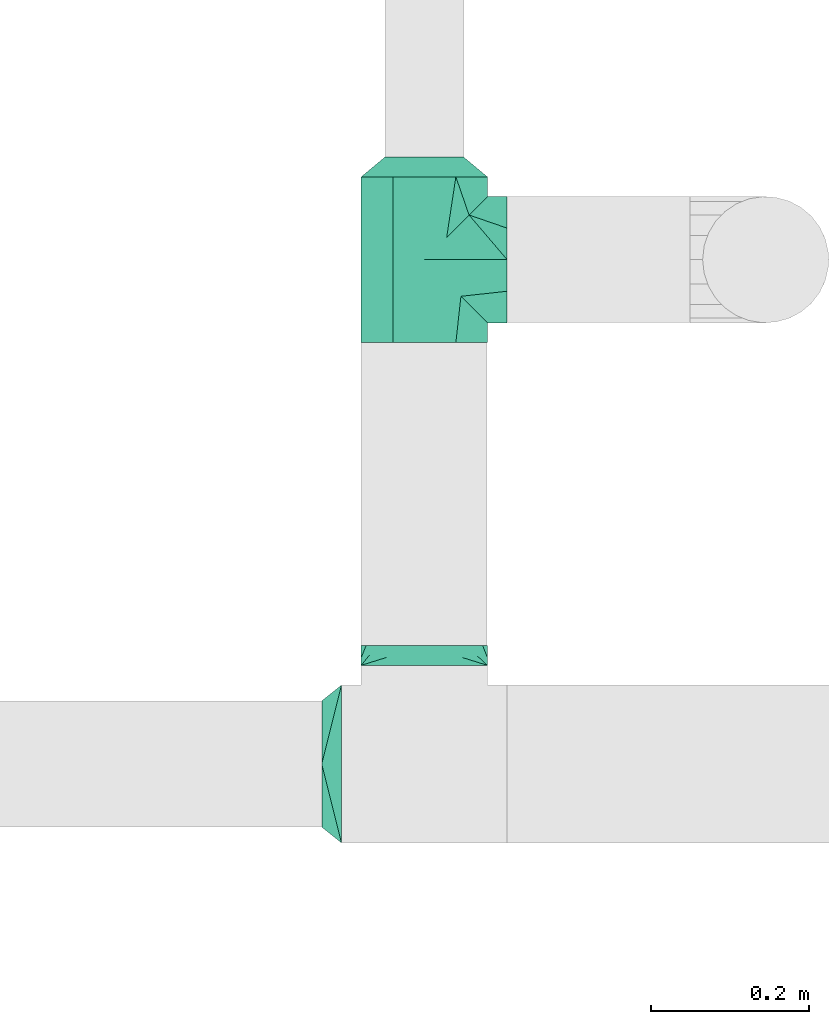
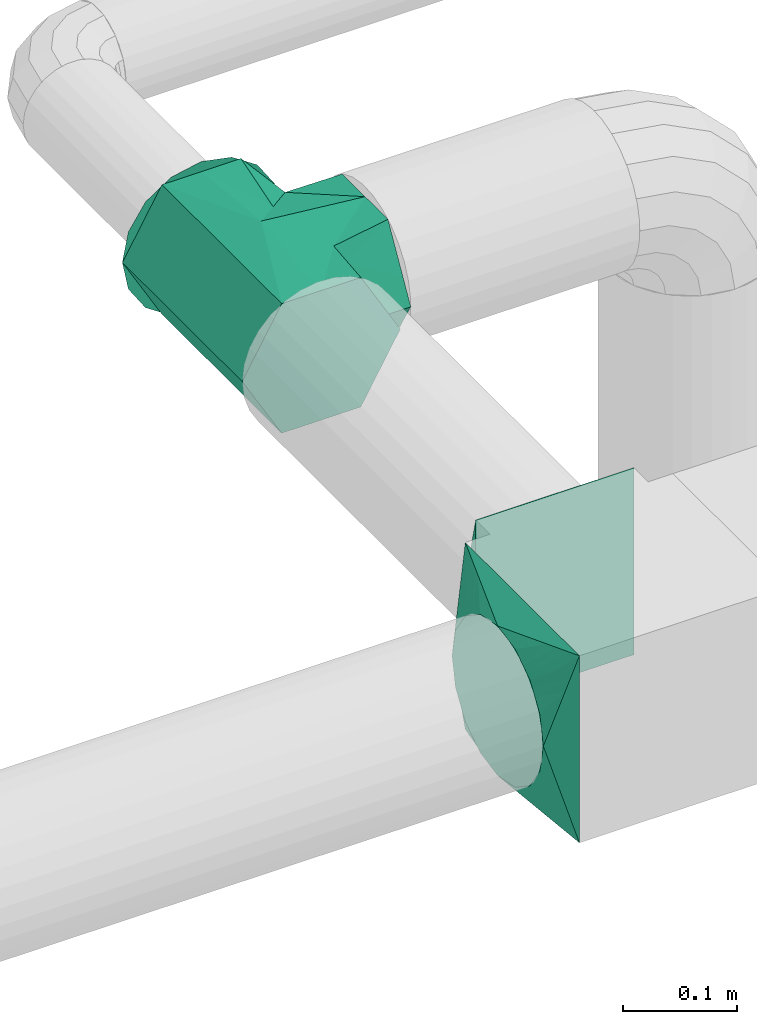
# One storey, part 4 of 5: 4 flow fittings.
"""IFC2X3 building model written with IfcOpenShell, lengths in millimetres."""

from ifc_helpers import new_model, entity, si_unit, converted_unit, derived_unit, direction, frame, origin, place, context, subcontext, project, spatial, faceted_brep, source, transform, mapped, material, material_list, type_object, type_shapes, element, save


model = new_model("IFC2X3")

# Units and contexts
model_context = context("Model", 3, precision=0.01, world=origin(), true_north=direction((6.12303176911189e-17, 1.0)))
body_context = subcontext(model_context, "Body", "Model", "MODEL_VIEW")
ifc_project = project(units=[si_unit("LENGTHUNIT", "METRE", prefix="MILLI"), si_unit("AREAUNIT", "SQUARE_METRE"), si_unit("VOLUMEUNIT", "CUBIC_METRE"), converted_unit("PLANEANGLEUNIT", "DEGREE", entity("IfcRatioMeasure", 0.0174532925199433), si_unit("PLANEANGLEUNIT", "RADIAN"), dimensions=[0, 0, 0, 0, 0, 0, 0]), si_unit("MASSUNIT", "GRAM", prefix="KILO"), derived_unit("MASSDENSITYUNIT", [(si_unit("MASSUNIT", "GRAM", prefix="KILO"), 1), (si_unit("LENGTHUNIT", "METRE"), -3)]), derived_unit("MOMENTOFINERTIAUNIT", [(si_unit("LENGTHUNIT", "METRE"), 4)]), si_unit("TIMEUNIT", "SECOND"), si_unit("FREQUENCYUNIT", "HERTZ"), si_unit("THERMODYNAMICTEMPERATUREUNIT", "DEGREE_CELSIUS"), derived_unit("THERMALTRANSMITTANCEUNIT", [(si_unit("MASSUNIT", "GRAM", prefix="KILO"), 1), (si_unit("THERMODYNAMICTEMPERATUREUNIT", "KELVIN"), -1), (si_unit("TIMEUNIT", "SECOND"), -3)]), derived_unit("VOLUMETRICFLOWRATEUNIT", [(si_unit("LENGTHUNIT", "METRE"), 3), (si_unit("TIMEUNIT", "SECOND"), -1)]), si_unit("ELECTRICCURRENTUNIT", "AMPERE"), si_unit("ELECTRICVOLTAGEUNIT", "VOLT"), si_unit("POWERUNIT", "WATT"), si_unit("FORCEUNIT", "NEWTON", prefix="KILO"), si_unit("ILLUMINANCEUNIT", "LUX"), si_unit("LUMINOUSFLUXUNIT", "LUMEN"), si_unit("LUMINOUSINTENSITYUNIT", "CANDELA"), derived_unit("USERDEFINED", [(si_unit("MASSUNIT", "GRAM", prefix="KILO"), -1), (si_unit("LENGTHUNIT", "METRE"), -2), (si_unit("TIMEUNIT", "SECOND"), 3), (si_unit("LUMINOUSFLUXUNIT", "LUMEN"), 1)]), derived_unit("LINEARVELOCITYUNIT", [(si_unit("LENGTHUNIT", "METRE"), 1), (si_unit("TIMEUNIT", "SECOND"), -1)]), si_unit("PRESSUREUNIT", "PASCAL"), derived_unit("USERDEFINED", [(si_unit("LENGTHUNIT", "METRE"), -2), (si_unit("MASSUNIT", "GRAM", prefix="KILO"), 1), (si_unit("TIMEUNIT", "SECOND"), -2)]), derived_unit("LINEARFORCEUNIT", [(si_unit("MASSUNIT", "GRAM", prefix="KILO"), 1), (si_unit("LENGTHUNIT", "METRE"), 1), (si_unit("TIMEUNIT", "SECOND"), -2), (si_unit("LENGTHUNIT", "METRE"), -1)]), derived_unit("PLANARFORCEUNIT", [(si_unit("MASSUNIT", "GRAM", prefix="KILO"), 1), (si_unit("LENGTHUNIT", "METRE"), 1), (si_unit("TIMEUNIT", "SECOND"), -2), (si_unit("LENGTHUNIT", "METRE"), -2)])], contexts=[model_context])

# Site, building, storey
site_placement = place(None, origin())
site = spatial("IfcSite", under=ifc_project, at=site_placement, CompositionType="ELEMENT")
building_placement = place(site_placement, origin())
building = spatial("IfcBuilding", under=site, at=building_placement, CompositionType="ELEMENT")
storey_placement = place(building_placement, frame((0.0, 0.0, 12000.0)))
storey = spatial("IfcBuildingStorey", under=building, at=storey_placement, Name="03 Level", CompositionType="ELEMENT", Elevation=12000.0)

# Flow fittings
duct_fitting_type_1 = type_object("IfcDuctFittingType", Name="tee_90_001:Air_Tee 90_Circ", PredefinedType="NOTDEFINED")
shared_shape_1 = source(origin(), body_context, "Body", "Brep", [
    faceted_brep([(-105.0, -40.0, -69.2820323027551), (-105.0, -60.0, -34.6410161513775), (-105.0, -80.0, 0.0), (-105.0, -60.0, 34.641016151378), (-105.0, -40.0, 69.2820323027556), (-105.0, 0.0, 69.2820323027551), (-105.0, 40.0, 69.2820323027547), (-105.0, 50.0, 51.9615242270659), (-105.0, 60.0, 34.6410161513772), (-105.0, 70.0, 17.3205080756885), (-105.0, 80.0, 0.0), (-105.0, 60.0, -34.6410161513777), (-105.0, 40.0, -69.2820323027552), (-105.0, 0.0, -69.2820323027551), (105.0, 80.0, 0.0), (105.0, 60.0, 34.6410161513772), (105.0, 40.0, 69.2820323027547), (105.0, 0.0, 69.2820323027551), (105.0, -40.0, 69.2820323027556), (105.0, -65.7984888459213, 24.5977388631201), (105.0, -80.0, 0.0), (105.0, -60.0, -34.6410161513775), (105.0, -40.0, -69.2820323027551), (105.0, 0.0, -69.2820323027551), (105.0, 40.0, -69.2820323027552), (105.0, 50.0, -51.9615242270664), (105.0, 60.0, -34.6410161513777), (105.0, 70.0, -17.320508075689), (63.1985060310392, 63.1985060310395, 32.5857226086492), (46.3970120620784, 46.3970120620786, 65.1714452172986), (80.0, 80.0, 0.0), (0.0, 0.0, 80.0), (-56.6842556369155, 56.6842556369154, 56.452592171563), (-68.3421278184578, 68.3421278184576, 28.2262960857814), (-28.3421278184578, 28.3421278184581, 68.2262960857815), (-74.1710639092289, 74.1710639092287, 14.1131480428906), (54.7977590465588, 54.7977590465591, 48.878583912974), (-74.6766712784703, 74.6766712784701, 12.8889603793856), (-80.0, 80.0, 0.0), (56.6842556369152, 56.6842556369155, -56.4525921715632), (-46.3970120620782, 46.3970120620781, -65.1714452172987), (0.0, 0.0, -80.0), (-63.1985060310391, 63.198506031039, -32.5857226086494), (28.3421278184576, 28.3421278184579, -68.2262960857816), (74.1710639092288, 74.1710639092291, -14.113148042891), (68.3421278184576, 68.3421278184579, -28.2262960857817), (74.6766712820988, 74.6766712820991, -12.8889603706002), (-80.0, 105.0, 0.0), (-60.0, 105.0, 34.6410161513772), (-40.0, 105.0, 69.2820323027547), (0.0, 105.0, 69.2820323027551), (40.0, 105.0, 69.2820323027556), (65.7984884413447, 105.0, 24.5977395638678), (80.0, 105.0, 0.0), (60.0, 105.0, -34.6410161513775), (40.0, 105.0, -69.2820323027551), (0.0, 105.0, -69.2820323027551), (-40.0, 105.0, -69.2820323027552), (-60.0, 105.0, -34.6410161513777), (-72.8992433944082, 105.0, -12.2988712130655)], [[[0, 1, 2, 3, 4, 5, 6, 7, 8, 9, 10, 11, 12, 13]], [[14, 15, 16, 17, 18, 19, 20, 21, 22, 23, 24, 25, 26, 27]], [[15, 14, 28]], [[16, 15, 29]], [[30, 28, 14]], [[5, 4, 31]], [[8, 32, 33]], [[8, 7, 6, 32]], [[34, 32, 6]], [[33, 35, 9]], [[31, 17, 29]], [[15, 28, 36, 29]], [[18, 17, 31]], [[2, 20, 19, 18, 4, 3]], [[6, 5, 34]], [[34, 5, 31]], [[9, 35, 10]], [[18, 31, 4]], [[9, 8, 33]], [[17, 16, 29]], [[10, 35, 37, 38]], [[21, 20, 2, 1, 0, 22]], [[25, 24, 39, 26]], [[12, 40, 13]], [[41, 22, 0]], [[41, 13, 40]], [[41, 0, 13]], [[42, 40, 11]], [[43, 24, 23]], [[27, 44, 14]], [[27, 45, 44]], [[27, 26, 45]], [[14, 44, 46, 30]], [[39, 45, 26]], [[43, 39, 24]], [[10, 42, 11]], [[38, 42, 10]], [[23, 22, 41]], [[12, 11, 40]], [[43, 23, 41]], [[47, 48, 49, 50, 51, 52, 53, 54, 55, 56, 57, 58, 59]], [[38, 37, 47]], [[28, 30, 52, 36]], [[33, 32, 48, 37, 35]], [[50, 49, 32]], [[51, 36, 52]], [[29, 36, 51]], [[31, 29, 50]], [[50, 32, 34, 31]], [[30, 53, 52]], [[32, 49, 48]], [[47, 37, 48]], [[29, 51, 50]], [[30, 46, 53]], [[54, 46, 44, 45, 39]], [[59, 58, 57, 42]], [[56, 55, 39]], [[39, 55, 54]], [[47, 59, 38]], [[40, 42, 57]], [[38, 59, 42]], [[56, 39, 43, 41]], [[41, 40, 56]], [[40, 57, 56]], [[53, 46, 54]]]),
])
type_shapes(duct_fitting_type_1, [shared_shape_1])
flow_fitting_1_placement = place(storey_placement, frame((23185.9900708518, -67867.2449387878, 3000.0), z_axis=(0.0, 0.0, 1.0), x_axis=(0.0, -1.0, 0.0)))
element("IfcFlowFitting", 1, at=flow_fitting_1_placement, inside=storey, type_object=duct_fitting_type_1, Name="tee_90_001:Air_Tee 90_Circ", ObjectType="tee_90_001:Air_Tee 90_Circ", context=body_context, shape_type="MappedRepresentation", body=[
    mapped(shared_shape_1, transform((0.0, 0.0, 0.0), scale=1.0)),
])
ifc_material_1 = material(Name="Material_Duct")
ifc_material_2 = material(Name="Material_Lining")
ifc_material_3 = material(Name="Material_Ins")
ifc_material_list_1 = material_list([ifc_material_2, ifc_material_3, ifc_material_1])
duct_fitting_type_2 = type_object("IfcDuctFittingType", Name="reduction_001:Air_Reduction_Circ", PredefinedType="NOTDEFINED", material=ifc_material_list_1)
shared_shape_2 = source(origin(), body_context, "Body", "Brep", [
    faceted_brep([(25.0, 45.0484433951223, -21.6941869558729), (25.0, 47.5242216975607, -10.8470934779334), (25.0, 50.0, 0.0), (25.0, 47.5242216975601, 10.8470934779448), (25.0, 45.0484433951193, 21.6941869558836), (25.0, 38.1114667440265, 30.3928805396443), (25.0, 31.1744900929338, 39.0915741234051), (25.0, 21.1502683953737, 43.9189848662489), (25.0, 11.1260466978137, 48.7463956090927), (25.0, 0.0, 48.7463956090925), (25.0, -11.1260466978156, 48.7463956090923), (25.0, -21.1502683953754, 43.9189848662482), (25.0, -31.1744900929351, 39.0915741234041), (25.0, -38.1114667440274, 30.3928805396434), (25.0, -45.0484433951197, 21.6941869558827), (25.0, -47.5242216975603, 10.8470934779443), (25.0, -50.0, 0.0), (25.0, -47.5242216975608, -10.8470934779335), (25.0, -45.0484433951224, -21.6941869558726), (25.0, -38.1114667440309, -30.3928805396354), (25.0, -31.1744900929393, -39.0915741233981), (25.0, -21.1502683953783, -43.9189848662439), (25.0, -11.1260466978174, -48.7463956090898), (25.0, 0.0, -48.7463956090899), (25.0, 11.1260466978161, -48.74639560909), (25.0, 21.1502683953773, -43.9189848662444), (25.0, 31.1744900929385, -39.0915741233988), (25.0, 38.1114667440304, -30.3928805396358), (0.0, 80.0, 0.0), (0.0, 76.9551813004531, -15.307337294604), (0.0, 73.9103626009062, -30.6146745892082), (0.0, 65.2394525479173, -43.5916085420681), (0.0, 56.5685424949284, -56.5685424949279), (0.0, 43.5916085420694, -65.2394525479189), (0.0, 30.6146745892104, -73.9103626009099), (0.0, 15.3073372946054, -76.9551813004588), (0.0, 0.0, -80.0), (0.0, -15.3073372946045, -76.9551813004584), (0.0, -30.6146745892093, -73.9103626009091), (0.0, -43.5916085420678, -65.239452547918), (0.0, -56.5685424949263, -56.568542494927), (0.0, -65.2394525479148, -43.5916085420674), (0.0, -73.9103626009034, -30.6146745892079), (0.0, -76.9551813004502, -15.3073372946042), (0.0, -80.0, 0.0), (0.0, -76.9551813004499, 15.3073372946029), (0.0, -73.9103626008998, 30.6146745892058), (0.0, -65.2394525479096, 43.5916085420626), (0.0, -56.5685424949195, 56.5685424949194), (0.0, -43.5916085420619, 65.2394525479076), (0.0, -30.6146745892043, 73.9103626008959), (0.0, -15.3073372946022, 76.955181300444), (0.0, 0.0, 80.0), (0.0, 15.3073372946022, 76.9551813004446), (0.0, 30.6146745892045, 73.910362600897), (0.0, 43.5916085420627, 65.2394525479091), (0.0, 56.5685424949208, 56.5685424949211), (0.0, 65.2394525479115, 43.5916085420641), (0.0, 73.9103626009022, 30.6146745892071), (0.0, 76.9551813004526, 15.3073372946037)], [[[0, 1, 2, 3, 4, 5, 6, 7, 8, 9, 10, 11, 12, 13, 14, 15, 16, 17, 18, 19, 20, 21, 22, 23, 24, 25, 26, 27]], [[28, 29, 30, 31, 32, 33, 34, 35, 36, 37, 38, 39, 40, 41, 42, 43, 44, 45, 46, 47, 48, 49, 50, 51, 52, 53, 54, 55, 56, 57, 58, 59]], [[17, 42, 18]], [[38, 21, 39]], [[18, 42, 41]], [[27, 32, 31]], [[23, 35, 24]], [[22, 37, 23]], [[33, 32, 26]], [[41, 19, 18]], [[44, 43, 16]], [[35, 23, 36]], [[20, 39, 21]], [[43, 17, 16]], [[22, 21, 38]], [[33, 26, 25]], [[1, 29, 2]], [[30, 0, 31]], [[35, 34, 24]], [[41, 40, 19]], [[40, 20, 19]], [[24, 34, 25]], [[25, 34, 33]], [[27, 31, 0]], [[43, 42, 17]], [[27, 26, 32]], [[0, 30, 1]], [[22, 38, 37]], [[28, 2, 29]], [[36, 23, 37]], [[1, 30, 29]], [[20, 40, 39]], [[3, 58, 4]], [[54, 7, 55]], [[4, 58, 57]], [[13, 48, 47]], [[9, 51, 10]], [[8, 53, 9]], [[49, 48, 12]], [[57, 5, 4]], [[28, 59, 2]], [[51, 9, 52]], [[6, 55, 7]], [[59, 3, 2]], [[8, 7, 54]], [[49, 12, 11]], [[15, 45, 16]], [[46, 14, 47]], [[51, 50, 10]], [[57, 56, 5]], [[56, 6, 5]], [[10, 50, 11]], [[11, 50, 49]], [[13, 47, 14]], [[59, 58, 3]], [[13, 12, 48]], [[14, 46, 15]], [[8, 54, 53]], [[44, 16, 45]], [[52, 9, 53]], [[15, 46, 45]], [[6, 56, 55]]]),
])
type_shapes(duct_fitting_type_2, [shared_shape_2])
flow_fitting_2_placement = place(storey_placement, frame((23185.9900708518, -67762.2449387878, 3000.0), z_axis=(0.0, 0.0, 1.0), x_axis=(0.0, 1.0, 0.0)))
element("IfcFlowFitting", 2, at=flow_fitting_2_placement, inside=storey, type_object=duct_fitting_type_2, material=ifc_material_1, Name="reduction_001:Air_Reduction_Circ", ObjectType="reduction_001:Air_Reduction_Circ", context=body_context, shape_type="MappedRepresentation", body=[
    mapped(shared_shape_2, transform((0.0, 0.0, 0.0), scale=1.0)),
])
ifc_material_list_2 = material_list([ifc_material_3, ifc_material_1, ifc_material_2])
duct_fitting_type_3 = type_object("IfcDuctFittingType", Name="multi_shape_trans_001:Air_Multi shape transition_Circ", PredefinedType="NOTDEFINED", material=ifc_material_list_2)
shared_shape_3 = source(origin(), body_context, "Body", "Brep", [
    faceted_brep([(25.0, 0.0, -80.0), (25.0, 7.55917892584856, -78.4963858244121), (25.0, 15.1183578516973, -76.9927716488251), (25.0, 22.8665162204521, -75.4515671248636), (25.0, 26.7405954048296, -74.6809648628828), (25.0, 30.614674589207, -73.9103626009021), (25.0, 37.1031415656362, -69.5749075744073), (25.0, 43.5916085420653, -65.2394525479126), (25.0, 50.0800755184945, -60.9039975214178), (25.0, 56.5685424949236, -56.5685424949231), (25.0, 60.9039975214184, -50.0800755184939), (25.0, 65.2394525479132, -43.5916085420648), (25.0, 69.574907574408, -37.1031415656356), (25.0, 73.9103626009028, -30.6146745892065), (25.0, 75.4515671268645, -22.8665162103963), (25.0, 76.9927716528262, -15.1183578315862), (25.0, 77.7445787396197, -11.3387683736895), (25.0, 78.4963858264131, -7.55917891579276), (25.0, 80.0, 0.0), (25.0, 78.496385824413, 7.55917892584876), (25.0, 76.992771648826, 15.1183578516975), (25.0, 75.4515671248645, 22.8665162204524), (25.0, 74.6809648628837, 26.7405954048298), (25.0, 73.9103626009029, 30.6146745892072), (25.0, 69.5749075744081, 37.1031415656364), (25.0, 65.2394525479133, 43.5916085420656), (25.0, 60.9039975214185, 50.0800755184947), (25.0, 56.5685424949237, 56.5685424949239), (25.0, 50.0800755184946, 60.9039975214187), (25.0, 43.5916085420654, 65.2394525479134), (25.0, 37.1031415656362, 69.5749075744082), (25.0, 30.6146745892071, 73.910362600903), (25.0, 22.8665162103969, 75.4515671268647), (25.0, 15.1183578315867, 76.9927716528263), (25.0, 11.33876837369, 77.7445787396197), (25.0, 7.55917891579327, 78.4963858264132), (25.0, 0.0, 80.0), (25.0, -7.55917892584888, 78.496385824413), (25.0, -15.1183578516976, 76.992771648826), (25.0, -22.8665162204525, 75.4515671248644), (25.0, -26.7405954048299, 74.6809648628836), (25.0, -30.6146745892073, 73.9103626009029), (25.0, -37.1031415656365, 69.5749075744081), (25.0, -43.5916085420656, 65.2394525479133), (25.0, -50.0800755184948, 60.9039975214185), (25.0, -56.5685424949239, 56.5685424949237), (25.0, -60.9039975214187, 50.0800755184945), (25.0, -65.2394525479135, 43.5916085420653), (25.0, -69.5749075744082, 37.1031415656362), (25.0, -73.910362600903, 30.614674589207), (25.0, -75.4515671268647, 22.8665162103968), (25.0, -76.9927716528263, 15.1183578315866), (25.0, -77.7445787396197, 11.3387683736899), (25.0, -78.4963858264131, 7.55917891579322), (25.0, -80.0, 0.0), (25.0, -78.496385824413, -7.55917892584782), (25.0, -76.992771648826, -15.1183578516966), (25.0, -75.4515671248645, -22.8665162204514), (25.0, -74.6809648628837, -26.7405954048289), (25.0, -73.910362600903, -30.6146745892063), (25.0, -69.5749075744082, -37.1031415656355), (25.0, -65.2394525479134, -43.5916085420646), (25.0, -60.9039975214186, -50.0800755184938), (25.0, -56.5685424949238, -56.5685424949229), (25.0, -50.0800755184946, -60.9039975214177), (25.0, -43.5916085420654, -65.2394525479125), (25.0, -37.1031415656363, -69.5749075744073), (25.0, -30.6146745892071, -73.9103626009021), (25.0, -22.8665162103969, -75.4515671268637), (25.0, -15.1183578315867, -76.9927716528254), (25.0, -11.33876837369, -77.7445787396188), (25.0, -7.55917891579331, -78.4963858264122), (0.0, -80.0, -100.0), (0.0, -80.0, 100.0), (0.0, 80.0, 100.0), (0.0, 80.0, -100.0), (9.76070875417778, 48.7657319866316, 92.1914329966588), (6.50713916945185, 59.1771546577547, 94.7942886644397), (3.25356948584772, 80.0, 86.9857220566105), (12.5000000004112, 69.9443399352347, 76.5204921859004), (22.0035694858477, 80.0, 11.9857220566093), (19.0071389716954, 80.0, 23.9714441132186), (16.0107084575432, 80.0, 35.957166169828), (13.0142779433909, 80.0, 47.9428882264372), (9.76070845754316, 80.0, 60.9571661698283), (13.0142783389037, 38.3543093155085, 89.5885773288778), (16.0107087541778, 28.7657319866313, 87.1914329966584), (19.0071391694519, 19.1771546577542, 84.7942886644389), (20.5053543770889, 14.3828659933156, 83.5957164983292), (22.0035695847259, 9.58857732887701, 82.3971443322195), (6.50713897169544, 80.0, 73.9714441132194), (3.25356958472593, 69.5885773288778, 97.3971443322206), (22.0035695847259, 80.0, -11.9857216610957), (20.5053543770889, 80.0, -17.9785824916439), (19.0071391694518, 80.0, -23.9714433221921), (16.0107087541778, 80.0, -35.9571649832885), (13.0142783389037, 80.0, -47.9428866443849), (9.76070875417777, 80.0, -60.9571649832887), (6.50713916945184, 80.0, -73.9714433221924), (3.25356958472592, 80.0, -86.9857216610962), (3.25356948584772, 69.5885776452881, -97.3971444113217), (12.5000000004112, 66.5204921862289, -79.9443399349049), (22.0035694858477, 9.58857764528726, -82.397144411321), (19.0071389716954, 19.1771552905747, -84.794288822643), (16.0107084575432, 28.7657329358621, -87.1914332339649), (13.0142779433909, 38.3543105811496, -89.5885776452868), (9.76070845754315, 48.7657329358624, -92.1914332339651), (6.50713897169543, 59.1771552905753, -94.7942888226434), (22.0035695847259, -9.58857732887686, -82.3971443322185), (20.5053543770889, -14.3828659933154, -83.5957164983281), (19.0071391694519, -19.1771546577538, -84.7942886644378), (16.0107087541778, -28.7657319866308, -87.1914329966572), (13.0142783389037, -38.3543093155078, -89.5885773288766), (9.76070875417778, -48.7657319866307, -92.1914329966574), (6.50713916945185, -59.1771546577536, -94.7942886644383), (3.25356958472593, -69.5885773288765, -97.3971443322191), (3.25356948584772, -80.0, -86.985722056609), (12.5000000004112, -69.9443399352339, -76.5204921858991), (22.0035694858477, -80.0, -11.9857220566083), (19.0071389716954, -80.0, -23.9714441132175), (16.0107084575432, -80.0, -35.9571661698268), (13.0142779433909, -80.0, -47.942888226436), (9.76070845754316, -80.0, -60.957166169827), (6.50713897169544, -80.0, -73.971444113218), (22.0035695847259, -80.0, 11.9857216610963), (20.5053543770889, -80.0, 17.9785824916446), (19.0071391694519, -80.0, 23.9714433221928), (16.0107087541778, -80.0, 35.9571649832894), (13.0142783389037, -80.0, 47.9428866443859), (9.76070875417777, -80.0, 60.9571649832898), (6.50713916945185, -80.0, 73.9714433221937), (3.25356958472593, -80.0, 86.9857216610977), (3.25356948584772, -69.5885776452868, 97.3971444113232), (12.5000000004112, -66.5204921862283, 79.9443399349061), (22.0035694858477, -9.58857764528735, 82.397144411322), (19.0071389716954, -19.1771552905746, 84.794288822644), (16.0107084575432, -28.7657329358618, 87.1914332339661), (13.0142779433909, -38.354310581149, 89.5885776452881), (9.76070845754316, -48.7657329358616, 92.1914332339665), (6.50713897169544, -59.1771552905742, 94.7942888226448)], [[[0, 1, 2, 3, 4, 5, 6, 7, 8, 9, 10, 11, 12, 13, 14, 15, 16, 17, 18, 19, 20, 21, 22, 23, 24, 25, 26, 27, 28, 29, 30, 31, 32, 33, 34, 35, 36, 37, 38, 39, 40, 41, 42, 43, 44, 45, 46, 47, 48, 49, 50, 51, 52, 53, 54, 55, 56, 57, 58, 59, 60, 61, 62, 63, 64, 65, 66, 67, 68, 69, 70, 71]], [[72, 73, 74, 75]], [[76, 29, 77]], [[76, 31, 30, 29]], [[78, 74, 79]], [[27, 79, 28]], [[20, 19, 18, 80, 81, 82, 83, 84, 23, 22, 21]], [[31, 76, 85, 86, 87, 88, 89, 36, 35, 34, 33, 32]], [[27, 26, 79]], [[90, 25, 84]], [[79, 74, 91]], [[84, 25, 24, 23]], [[26, 25, 90]], [[78, 79, 26]], [[78, 26, 90]], [[29, 28, 77]], [[91, 77, 28]], [[91, 28, 79]], [[75, 74, 78, 90, 84, 83, 82, 81, 80, 18, 92, 93, 94, 95, 96, 97, 98, 99]], [[97, 11, 98]], [[97, 13, 12, 11]], [[100, 75, 101]], [[9, 101, 10]], [[2, 1, 0, 102, 103, 104, 105, 106, 5, 4, 3]], [[13, 97, 96, 95, 94, 93, 92, 18, 17, 16, 15, 14]], [[9, 8, 101]], [[107, 7, 106]], [[101, 75, 99]], [[106, 7, 6, 5]], [[8, 7, 107]], [[100, 101, 8]], [[100, 8, 107]], [[11, 10, 98]], [[99, 98, 10]], [[99, 10, 101]], [[72, 75, 100, 107, 106, 105, 104, 103, 102, 0, 108, 109, 110, 111, 112, 113, 114, 115]], [[113, 65, 114]], [[113, 67, 66, 65]], [[116, 72, 117]], [[63, 117, 64]], [[56, 55, 54, 118, 119, 120, 121, 122, 59, 58, 57]], [[67, 113, 112, 111, 110, 109, 108, 0, 71, 70, 69, 68]], [[63, 62, 117]], [[123, 61, 122]], [[117, 72, 115]], [[122, 61, 60, 59]], [[62, 61, 123]], [[116, 117, 62]], [[116, 62, 123]], [[65, 64, 114]], [[115, 114, 64]], [[115, 64, 117]], [[124, 125, 126, 127, 128, 129, 130, 131, 73, 72, 116, 123, 122, 121, 120, 119, 118, 54]], [[129, 47, 130]], [[129, 49, 48, 47]], [[132, 73, 133]], [[45, 133, 46]], [[38, 37, 36, 134, 135, 136, 137, 138, 41, 40, 39]], [[49, 129, 128, 127, 126, 125, 124, 54, 53, 52, 51, 50]], [[45, 44, 133]], [[139, 43, 138]], [[133, 73, 131]], [[138, 43, 42, 41]], [[44, 43, 139]], [[132, 133, 44]], [[132, 44, 139]], [[47, 46, 130]], [[131, 130, 46]], [[131, 46, 133]], [[89, 88, 87, 86, 85, 76, 77, 91, 74, 73, 132, 139, 138, 137, 136, 135, 134, 36]]]),
])
type_shapes(duct_fitting_type_3, [shared_shape_3])
flow_fitting_3_placement = place(storey_placement, frame((23185.9900708518, -68381.4439409626, 3000.0), z_axis=(0.0, 0.0, 1.0), x_axis=(0.0, 1.0, 0.0)))
element("IfcFlowFitting", 3, at=flow_fitting_3_placement, inside=storey, type_object=duct_fitting_type_3, material=ifc_material_1, Name="multi_shape_trans_001:Air_Multi shape transition_Circ", ObjectType="multi_shape_trans_001:Air_Multi shape transition_Circ", context=body_context, shape_type="MappedRepresentation", body=[
    mapped(shared_shape_3, transform((0.0, 0.0, 0.0), scale=1.0)),
])
ifc_material_list_3 = material_list([ifc_material_3, ifc_material_1, ifc_material_2])
duct_fitting_type_4 = type_object("IfcDuctFittingType", Name="multi_shape_trans_001:Air_Multi shape transition_Circ", PredefinedType="NOTDEFINED", material=ifc_material_list_3)
shared_shape_4 = source(origin(), body_context, "Body", "Brep", [
    faceted_brep([(25.0, 0.0, -80.0), (25.0, 7.55917892584856, -78.4963858244121), (25.0, 15.1183578516973, -76.9927716488251), (25.0, 22.8665162204521, -75.4515671248636), (25.0, 26.7405954048296, -74.6809648628828), (25.0, 30.614674589207, -73.9103626009021), (25.0, 37.1031415656362, -69.5749075744073), (25.0, 43.5916085420653, -65.2394525479126), (25.0, 50.0800755184945, -60.9039975214178), (25.0, 56.5685424949236, -56.5685424949231), (25.0, 60.9039975214184, -50.0800755184939), (25.0, 65.2394525479132, -43.5916085420648), (25.0, 69.574907574408, -37.1031415656356), (25.0, 73.9103626009028, -30.6146745892065), (25.0, 75.4515671268645, -22.8665162103963), (25.0, 76.9927716528262, -15.1183578315862), (25.0, 77.7445787396197, -11.3387683736895), (25.0, 78.4963858264131, -7.55917891579276), (25.0, 80.0, 0.0), (25.0, 78.496385824413, 7.55917892584876), (25.0, 76.992771648826, 15.1183578516975), (25.0, 75.4515671248645, 22.8665162204524), (25.0, 74.6809648628837, 26.7405954048298), (25.0, 73.9103626009029, 30.6146745892072), (25.0, 69.5749075744081, 37.1031415656364), (25.0, 65.2394525479133, 43.5916085420656), (25.0, 60.9039975214185, 50.0800755184947), (25.0, 56.5685424949237, 56.5685424949239), (25.0, 50.0800755184946, 60.9039975214187), (25.0, 43.5916085420654, 65.2394525479134), (25.0, 37.1031415656362, 69.5749075744082), (25.0, 30.6146745892071, 73.910362600903), (25.0, 22.8665162103969, 75.4515671268647), (25.0, 15.1183578315867, 76.9927716528263), (25.0, 11.33876837369, 77.7445787396197), (25.0, 7.55917891579326, 78.4963858264132), (25.0, 0.0, 80.0), (25.0, -7.55917892584888, 78.496385824413), (25.0, -15.1183578516976, 76.992771648826), (25.0, -22.8665162204525, 75.4515671248644), (25.0, -26.7405954048299, 74.6809648628836), (25.0, -30.6146745892073, 73.9103626009029), (25.0, -37.1031415656365, 69.5749075744081), (25.0, -43.5916085420656, 65.2394525479133), (25.0, -50.0800755184948, 60.9039975214185), (25.0, -56.5685424949239, 56.5685424949237), (25.0, -60.9039975214187, 50.0800755184945), (25.0, -65.2394525479135, 43.5916085420653), (25.0, -69.5749075744082, 37.1031415656362), (25.0, -73.910362600903, 30.614674589207), (25.0, -75.4515671268647, 22.8665162103968), (25.0, -76.9927716528263, 15.1183578315866), (25.0, -77.7445787396197, 11.3387683736899), (25.0, -78.4963858264131, 7.55917891579322), (25.0, -80.0, 0.0), (25.0, -78.496385824413, -7.55917892584782), (25.0, -76.992771648826, -15.1183578516966), (25.0, -75.4515671248645, -22.8665162204514), (25.0, -74.6809648628837, -26.7405954048289), (25.0, -73.910362600903, -30.6146745892063), (25.0, -69.5749075744082, -37.1031415656355), (25.0, -65.2394525479134, -43.5916085420646), (25.0, -60.9039975214186, -50.0800755184938), (25.0, -56.5685424949238, -56.5685424949229), (25.0, -50.0800755184946, -60.9039975214177), (25.0, -43.5916085420654, -65.2394525479125), (25.0, -37.1031415656363, -69.5749075744073), (25.0, -30.6146745892071, -73.9103626009021), (25.0, -22.8665162103969, -75.4515671268637), (25.0, -15.1183578315867, -76.9927716528254), (25.0, -11.33876837369, -77.7445787396188), (25.0, -7.55917891579331, -78.4963858264122), (0.0, -100.0, -100.0), (0.0, -100.0, 100.0), (0.0, 100.0, 100.0), (0.0, 100.0, -100.0), (9.76070875417778, 60.9571649832894, 92.1914329966587), (6.50713916945185, 73.9714433221932, 94.7942886644397), (3.25356948584772, 97.3971444113226, 86.9857220566105), (12.5000000004112, 79.9443399349057, 76.5204921859004), (22.0035694858477, 82.3971444113219, 11.9857220566093), (19.0071389716954, 84.7942888226439, 23.9714441132186), (16.0107084575432, 87.1914332339658, 35.9571661698279), (13.0142779433909, 89.5885776452877, 47.9428882264372), (9.76070845754317, 92.191433233966, 60.9571661698283), (13.0142783389037, 47.9428866443855, 89.5885773288778), (16.0107087541778, 35.9571649832891, 87.1914329966584), (19.0071391694519, 23.9714433221927, 84.7942886644389), (20.5053543770889, 17.9785824916445, 83.5957164983292), (22.0035695847259, 11.9857216610963, 82.3971443322195), (6.50713897169544, 94.7942888226443, 73.9714441132194), (3.25356958472593, 86.9857216610971, 97.3971443322206), (22.0035695847259, 82.3971443322194, -11.9857216610957), (20.5053543770889, 83.595716498329, -17.9785824916439), (19.0071391694518, 84.7942886644387, -23.9714433221921), (16.0107087541778, 87.1914329966581, -35.9571649832885), (13.0142783389037, 89.5885773288775, -47.9428866443849), (9.76070875417777, 92.1914329966583, -60.9571649832887), (6.50713916945184, 94.7942886644392, -73.9714433221924), (3.25356958472592, 97.3971443322201, -86.9857216610962), (3.25356948584772, 86.9857220566099, -97.3971444113217), (12.5000000004112, 76.5204921859, -79.9443399349049), (22.0035694858477, 11.9857220566091, -82.397144411321), (19.0071389716954, 23.9714441132183, -84.794288822643), (16.0107084575432, 35.9571661698276, -87.1914332339649), (13.0142779433909, 47.9428882264369, -89.5885776452868), (9.76070845754315, 60.9571661698279, -92.1914332339651), (6.50713897169543, 73.9714441132189, -94.7942888226434), (22.0035695847259, -11.9857216610961, -82.3971443322185), (20.5053543770889, -17.9785824916442, -83.5957164983281), (19.0071391694519, -23.9714433221924, -84.7942886644378), (16.0107087541778, -35.9571649832886, -87.1914329966572), (13.0142783389037, -47.9428866443848, -89.5885773288766), (9.76070875417778, -60.9571649832885, -92.1914329966574), (6.50713916945185, -73.9714433221921, -94.7942886644383), (3.25356958472593, -86.9857216610957, -97.3971443322191), (3.25356948584772, -97.3971444113213, -86.985722056609), (12.5000000004112, -79.944339934905, -76.5204921858991), (22.0035694858477, -82.3971444113218, -11.9857220566083), (19.0071389716954, -84.7942888226435, -23.9714441132175), (16.0107084575432, -87.1914332339653, -35.9571661698268), (13.0142779433909, -89.588577645287, -47.942888226436), (9.76070845754316, -92.1914332339651, -60.957166169827), (6.50713897169544, -94.7942888226432, -73.971444113218), (22.0035695847259, -82.3971443322192, 11.9857216610963), (20.5053543770889, -83.5957164983288, 17.9785824916446), (19.0071391694519, -84.7942886644384, 23.9714433221928), (16.0107087541778, -87.1914329966576, 35.9571649832894), (13.0142783389037, -89.5885773288767, 47.9428866443859), (9.76070875417777, -92.1914329966574, 60.9571649832898), (6.50713916945185, -94.7942886644381, 73.9714433221937), (3.25356958472593, -97.3971443322187, 86.9857216610977), (3.25356948584772, -86.9857220566086, 97.3971444113232), (12.5000000004112, -76.5204921858994, 79.9443399349061), (22.0035694858477, -11.9857220566092, 82.397144411322), (19.0071389716954, -23.9714441132182, 84.794288822644), (16.0107084575432, -35.9571661698272, 87.1914332339661), (13.0142779433909, -47.9428882264363, 89.5885776452881), (9.76070845754316, -60.957166169827, 92.1914332339665), (6.50713897169544, -73.9714441132178, 94.7942888226448)], [[[0, 1, 2, 3, 4, 5, 6, 7, 8, 9, 10, 11, 12, 13, 14, 15, 16, 17, 18, 19, 20, 21, 22, 23, 24, 25, 26, 27, 28, 29, 30, 31, 32, 33, 34, 35, 36, 37, 38, 39, 40, 41, 42, 43, 44, 45, 46, 47, 48, 49, 50, 51, 52, 53, 54, 55, 56, 57, 58, 59, 60, 61, 62, 63, 64, 65, 66, 67, 68, 69, 70, 71]], [[72, 73, 74, 75]], [[76, 29, 77]], [[76, 31, 30, 29]], [[78, 74, 79]], [[27, 79, 28]], [[20, 19, 18, 80, 81, 82, 83, 84, 23, 22, 21]], [[31, 76, 85, 86, 87, 88, 89, 36, 35, 34, 33, 32]], [[27, 26, 79]], [[90, 25, 84]], [[79, 74, 91]], [[84, 25, 24, 23]], [[26, 25, 90]], [[78, 79, 26]], [[78, 26, 90]], [[29, 28, 77]], [[91, 77, 28]], [[91, 28, 79]], [[75, 74, 78, 90, 84, 83, 82, 81, 80, 18, 92, 93, 94, 95, 96, 97, 98, 99]], [[97, 11, 98]], [[97, 13, 12, 11]], [[100, 75, 101]], [[9, 101, 10]], [[2, 1, 0, 102, 103, 104, 105, 106, 5, 4, 3]], [[13, 97, 96, 95, 94, 93, 92, 18, 17, 16, 15, 14]], [[9, 8, 101]], [[107, 7, 106]], [[101, 75, 99]], [[106, 7, 6, 5]], [[8, 7, 107]], [[100, 101, 8]], [[100, 8, 107]], [[11, 10, 98]], [[99, 98, 10]], [[99, 10, 101]], [[72, 75, 100, 107, 106, 105, 104, 103, 102, 0, 108, 109, 110, 111, 112, 113, 114, 115]], [[113, 65, 114]], [[113, 67, 66, 65]], [[116, 72, 117]], [[63, 117, 64]], [[56, 55, 54, 118, 119, 120, 121, 122, 59, 58, 57]], [[67, 113, 112, 111, 110, 109, 108, 0, 71, 70, 69, 68]], [[63, 62, 117]], [[123, 61, 122]], [[117, 72, 115]], [[122, 61, 60, 59]], [[62, 61, 123]], [[116, 117, 62]], [[116, 62, 123]], [[65, 64, 114]], [[115, 114, 64]], [[115, 64, 117]], [[124, 125, 126, 127, 128, 129, 130, 131, 73, 72, 116, 123, 122, 121, 120, 119, 118, 54]], [[129, 47, 130]], [[129, 49, 48, 47]], [[132, 73, 133]], [[45, 133, 46]], [[38, 37, 36, 134, 135, 136, 137, 138, 41, 40, 39]], [[49, 129, 128, 127, 126, 125, 124, 54, 53, 52, 51, 50]], [[45, 44, 133]], [[139, 43, 138]], [[133, 73, 131]], [[138, 43, 42, 41]], [[44, 43, 139]], [[132, 133, 44]], [[132, 44, 139]], [[47, 46, 130]], [[131, 130, 46]], [[131, 46, 133]], [[89, 88, 87, 86, 85, 76, 77, 91, 74, 73, 132, 139, 138, 137, 136, 135, 134, 36]]]),
])
type_shapes(duct_fitting_type_4, [shared_shape_4])
flow_fitting_4_placement = place(storey_placement, frame((23080.9900708518, -68506.4439409626, 3000.0), z_axis=(0.0, 0.0, 1.0), x_axis=(-1.0, 0.0, 0.0)))
element("IfcFlowFitting", 4, at=flow_fitting_4_placement, inside=storey, type_object=duct_fitting_type_4, material=ifc_material_1, Name="multi_shape_trans_001:Air_Multi shape transition_Circ", ObjectType="multi_shape_trans_001:Air_Multi shape transition_Circ", context=body_context, shape_type="MappedRepresentation", body=[
    mapped(shared_shape_4, transform((0.0, 0.0, 0.0), scale=1.0)),
])

save(model, "model.ifc")
